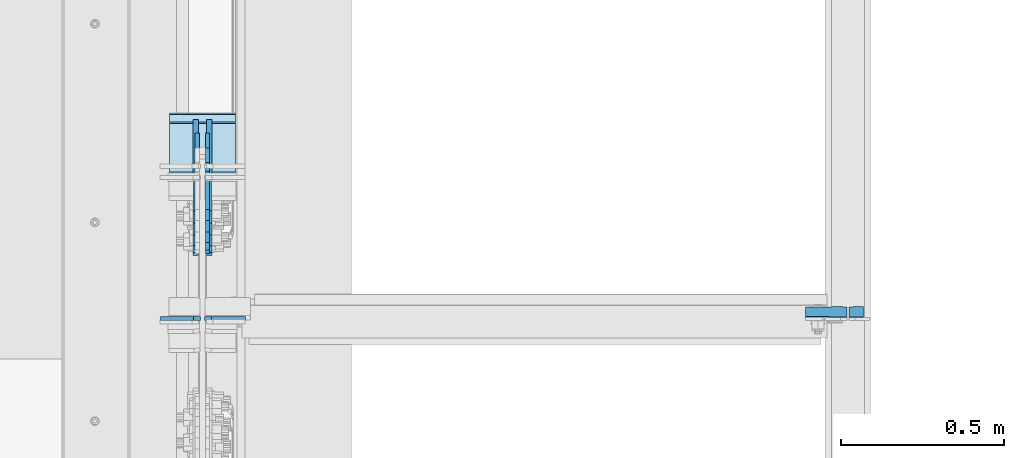
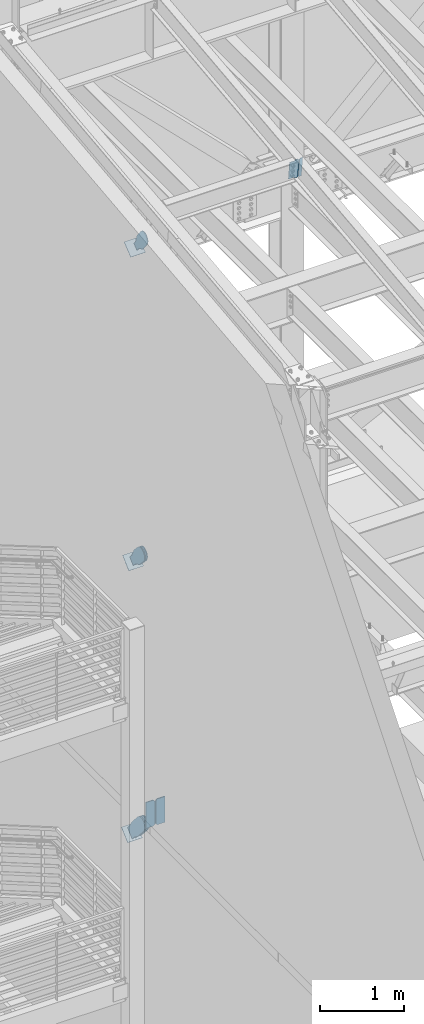
# One storey, part 1025 of 1179: 12 plates, 10 elements without a shape of their own.
"""IFC2X3 building model written with IfcOpenShell, lengths in millimetres."""

from ifc_helpers import new_model, si_unit, frame, origin_with_axes, place, context, subcontext, project, spatial, faceted_brep, material, type_object, element, aggregate, save


model = new_model("IFC2X3")

# Units and contexts
model_context = context("Model", 3, precision=1e-05, world=origin_with_axes())
body_context = subcontext(model_context, "Body", "Model", "MODEL_VIEW")
ifc_project = project(units=[si_unit("LENGTHUNIT", "METRE", prefix="MILLI"), si_unit("AREAUNIT", "SQUARE_METRE"), si_unit("VOLUMEUNIT", "CUBIC_METRE"), si_unit("MASSUNIT", "GRAM", prefix="KILO"), si_unit("TIMEUNIT", "SECOND"), si_unit("PLANEANGLEUNIT", "RADIAN"), si_unit("SOLIDANGLEUNIT", "STERADIAN"), si_unit("THERMODYNAMICTEMPERATUREUNIT", "DEGREE_CELSIUS"), si_unit("LUMINOUSINTENSITYUNIT", "LUMEN")], contexts=[model_context])

# Site, building, storey
site_placement = place(None, origin_with_axes())
site = spatial("IfcSite", under=ifc_project, at=site_placement, CompositionType="ELEMENT")
building_placement = place(site_placement, origin_with_axes())
building = spatial("IfcBuilding", under=site, at=building_placement, Name="Undefined", CompositionType="ELEMENT")
storey_placement = place(building_placement, origin_with_axes())
storey = spatial("IfcBuildingStorey", under=building, at=storey_placement, Name="Undefined", CompositionType="ELEMENT", Elevation=0.0)

# Assembly, plates
assembly_1_placement = place(storey_placement, origin_with_axes())
assembly_1 = element("IfcElementAssembly", 1, at=assembly_1_placement, inside=storey, Name="BEAM", AssemblyPlace="NOTDEFINED", PredefinedType="RIGID_FRAME")
ifc_material_1 = material(Name="STEEL/A36")
plate_type_1 = type_object("IfcPlateType", PredefinedType="NOTDEFINED")
plate_1_placement = place(assembly_1_placement, frame((2416.175, 30762.7083222141, 12422.6760116434), z_axis=(0.0, -0.112284087038017, 0.993676146336441), x_axis=(1.0, 0.0, 0.0)))
plate_1 = element("IfcPlate", 2, at=plate_1_placement, type_object=plate_type_1, material=ifc_material_1, Name="PLATE", context=body_context, shape_type="Brep", body=[
    faceted_brep([(-2.72848410531878e-12, -4.76249999998981, 12.6999998092615), (-5.54791768081486e-11, -4.76249999988249, 273.050000190095), (-5.54791768081486e-11, 4.76250000010987, 273.050000190089), (-2.72848410531878e-12, 4.76250000000437, 12.699999809256), (12.6999998092069, -4.76249999987886, 285.749999999351), (12.6999998092069, 4.76250000011532, 285.749999999349), (44.450000005796, -4.76249999988067, 285.749999998694), (44.450000005796, 4.7625000001135, 285.74999999869), (44.4500000000007, -4.76250000000073, 0.0), (44.4500000000007, 4.76250000000073, 0.0), (12.6999998092651, -4.76249999999527, 1.81898940354586e-12), (12.6999998092651, 4.76250000000073, 0.0)], [[[0, 1, 2, 3]], [[1, 4, 5, 2]], [[4, 6, 7, 5]], [[6, 8, 9, 7]], [[8, 10, 11, 9]], [[10, 0, 3, 11]], [[5, 7, 9, 11, 3, 2]], [[10, 8, 6, 4, 1, 0]]]),
])
plate_type_2 = type_object("IfcPlateType", PredefinedType="NOTDEFINED")
plate_2_placement = place(assembly_1_placement, frame((2409.825, 30730.6226475522, 12706.6189143206), z_axis=(-1.0, 0.0, 0.0), x_axis=(0.0, 0.112284087038014, -0.993676146336441)))
plate_2 = element("IfcPlate", 3, at=plate_2_placement, type_object=plate_type_2, material=ifc_material_1, Name="PLATE", context=body_context, shape_type="Brep", body=[
    faceted_brep([(273.049999995341, -4.76249999988795, 127.0), (273.049999995888, -4.76249999988795, 60.3249998091615), (273.049999995885, 4.76250000010623, 60.3249998091615), (273.049999995339, 4.76250000010623, 127.0), (274.016729918505, -4.76249999988795, 55.4649202911478), (274.0167299185, 4.76250000010623, 55.4649202911478), (276.769743818986, -4.76249999988795, 51.3447438230296), (276.769743818983, 4.76250000010623, 51.3447438230296), (280.889920287118, -4.76249999988431, 48.5917299225785), (280.889920287116, 4.76250000010987, 48.5917299225785), (285.749999805133, -4.76249999988431, 47.6250000000005), (285.749999999514, 4.7625000001135, 47.6250000000005), (12.6999999979416, -4.76249999999345, 127.0), (12.699999997938, 4.76250000000073, 127.0), (12.699999997998, 4.76250000000073, 60.324999809277), (12.6999999980017, -4.76249999999345, 60.324999809277), (11.7332700754141, 4.76250000000073, 55.4649202912278), (11.7332700754177, -4.76249999999345, 55.4649202912278), (8.98025617494022, 4.76249999999709, 51.3447438230705), (8.98025617494568, -4.76249999999345, 51.3447438230705), (4.86007970679384, 4.76249999999709, 48.5917299225894), (4.8600797067993, -4.76249999999709, 48.5917299225894), (-3.63797880709171e-12, 4.76249999999709, 47.6250000000005), (0.0, -4.76250000000073, 47.6250000000005), (-2.72848410531878e-12, 4.76250000000437, 12.699999809256), (-2.72848410531878e-12, -4.76249999998981, 12.6999998092615), (12.6999998092651, -4.76249999999527, 1.81898940354586e-12), (12.6999998092651, 4.76250000000073, 0.0), (273.050000190497, -4.76249999988977, -5.59339241590351e-11), (273.050000190493, 4.76250000010623, -5.59339241590351e-11), (285.749999999753, -4.76249999988249, 12.6999998092065), (285.749999999747, 4.76250000011169, 12.6999998092065)], [[[0, 1, 2, 3]], [[4, 5, 2, 1]], [[6, 7, 5, 4]], [[8, 9, 7, 6]], [[10, 11, 9, 8]], [[12, 13, 14, 15]], [[15, 14, 16, 17]], [[17, 16, 18, 19]], [[19, 18, 20, 21]], [[21, 20, 22, 23]], [[24, 25, 23, 22]], [[26, 25, 24, 27]], [[28, 26, 27, 29]], [[30, 28, 29, 31]], [[6, 4, 1, 0, 12, 15, 17, 19, 21, 23, 25, 26, 28, 30, 10, 8]], [[13, 12, 0, 3]], [[31, 29, 27, 24, 22, 20, 18, 16, 14, 13, 3, 2, 5, 7, 9, 11]], [[30, 31, 11, 10]]]),
])
aggregate(assembly_1, [plate_1, plate_2])

# Assembly, plate
assembly_2_placement = place(storey_placement, origin_with_axes())
assembly_2 = element("IfcElementAssembly", 4, at=assembly_2_placement, inside=storey, AssemblyPlace="NOTDEFINED", PredefinedType="RIGID_FRAME")
plate_type_3 = type_object("IfcPlateType", PredefinedType="NOTDEFINED")
plate_3_placement = place(assembly_2_placement, frame((447.675000000002, 31210.0093415497, 11898.2274613016), z_axis=(0.0, -0.784152810390105, -0.620567780308727), x_axis=(0.0, 0.620567780308723, -0.784152810390108)))
plate_3 = element("IfcPlate", 5, at=plate_3_placement, type_object=plate_type_3, material=ifc_material_1, context=body_context, shape_type="Brep", body=[
    faceted_brep([(0.0, -6.34999999999854, 0.0), (-101.600000000211, -6.34999999999854, -44.6881937825565), (-101.600000000211, 6.34999999999854, -44.6881937825565), (0.0, 6.34999999999854, 0.0), (-246.684985848258, -6.34999999999854, -44.6881937827675), (-246.684985848258, 6.34999999999854, -44.6881937827675), (-281.313054102191, -6.34999999999854, -37.800242748639), (-281.313054102191, 6.34999999999854, -37.800242748639), (-310.669312868691, -6.34999999999854, -18.1850177516608), (-310.669312868691, 6.34999999999854, -18.1850177516608), (-330.284537865713, -6.34999999999854, 11.1712410148393), (-330.284537865713, 6.34999999999854, 11.1712410148393), (-337.172488899912, -6.34999999999854, 45.7993031647638), (-337.172488899912, 6.34999999999854, 45.7993031647638), (-330.284537865768, -6.34999999999854, 80.4273714187839), (-330.284537865768, 6.34999999999854, 80.4273714187839), (-310.669312868773, -6.34999999999854, 109.783630185371), (-310.669312868773, 6.34999999999854, 109.783630185371), (-281.313054102271, -6.34999999999854, 129.398855182466), (-281.313054102271, 6.34999999999854, 129.398855182466), (-246.684988899762, -6.34999999999854, 136.286806216707), (-246.684988899762, 6.34999999999854, 136.286806216707), (-101.600000000377, -6.34999999999854, 136.286806216911), (-101.600000000377, 6.34999999999854, 136.286806216911), (-8.18545231595635e-11, -6.34999999999854, 91.5986124346418), (-8.18545231595635e-11, 6.34999999999854, 91.5986124346418), (71.7550000025622, -6.35000000000002, 91.5986124349001), (71.7550000025622, 6.35000000000002, 91.5986124349001), (71.7550000025931, -6.35000000000002, 1.09139364212751e-10), (71.7550000025931, 6.35000000000002, 1.09139364212751e-10)], [[[0, 1, 2, 3]], [[1, 4, 5, 2]], [[4, 6, 7, 5]], [[6, 8, 9, 7]], [[8, 10, 11, 9]], [[10, 12, 13, 11]], [[12, 14, 15, 13]], [[14, 16, 17, 15]], [[16, 18, 19, 17]], [[18, 20, 21, 19]], [[20, 22, 23, 21]], [[22, 24, 25, 23]], [[24, 26, 27, 25]], [[26, 28, 29, 27]], [[28, 0, 3, 29]], [[5, 7, 9, 11, 13, 15, 17, 19, 21, 23, 25, 27, 29, 3, 2]], [[28, 26, 24, 22, 20, 18, 16, 14, 12, 10, 8, 6, 4, 1, 0]]]),
])
aggregate(assembly_2, [plate_3])

assembly_3_placement = place(storey_placement, origin_with_axes())
assembly_3 = element("IfcElementAssembly", 6, at=assembly_3_placement, inside=storey, Name="Plate", AssemblyPlace="NOTDEFINED", PredefinedType="RIGID_FRAME")
plate_type_4 = type_object("IfcPlateType", PredefinedType="NOTDEFINED")
plate_4_placement = place(assembly_3_placement, frame((330.200000000002, 31136.984299702, 11752.9790012819), z_axis=(0.0, 0.784152810390107, 0.620567780308724), x_axis=(1.0, 0.0, 0.0)))
plate_4 = element("IfcPlate", 7, at=plate_4_placement, type_object=plate_type_4, material=ifc_material_1, Name="Plate", context=body_context, shape_type="Brep", body=[
    faceted_brep([(0.0, -3.17500000000109, 0.0), (0.0, -3.17500000000291, 203.200000000368), (0.0, 3.17499999998836, 203.200000000361), (0.0, 3.17500000000109, 7.27595761418343e-12), (203.199999999997, -3.17500000000291, 203.200000000368), (203.199999999997, 3.17499999998836, 203.200000000361), (203.199999999997, -3.17499999999927, 3.63797880709171e-12), (203.199999999997, 3.17499999999382, -3.63797880709171e-12)], [[[0, 1, 2, 3]], [[1, 4, 5, 2]], [[4, 6, 7, 5]], [[6, 0, 3, 7]], [[5, 7, 3, 2]], [[6, 4, 1, 0]]]),
])
aggregate(assembly_3, [plate_4])

assembly_4_placement = place(storey_placement, origin_with_axes())
assembly_4 = element("IfcElementAssembly", 8, at=assembly_4_placement, inside=storey, Name="Plate", AssemblyPlace="NOTDEFINED", PredefinedType="RIGID_FRAME")
plate_5_placement = place(assembly_4_placement, frame((330.200000000002, 31183.7164897158, 7162.85000799674), z_axis=(0.0, 0.729241792887681, 0.684256097894612), x_axis=(1.0, 0.0, 0.0)))
plate_5 = element("IfcPlate", 9, at=plate_5_placement, type_object=plate_type_4, material=ifc_material_1, Name="Plate", context=body_context, shape_type="Brep", body=[
    faceted_brep([(0.0, -3.17500000000109, 0.0), (0.0, -3.17500000000291, 203.200000000368), (0.0, 3.17499999998836, 203.200000000361), (0.0, 3.17500000000109, 7.27595761418343e-12), (203.199999999997, -3.17500000000291, 203.200000000368), (203.199999999997, 3.17499999998836, 203.200000000361), (203.199999999997, -3.17499999999927, 3.63797880709171e-12), (203.199999999997, 3.17499999999382, -3.63797880709171e-12)], [[[0, 1, 2, 3]], [[1, 4, 5, 2]], [[4, 6, 7, 5]], [[6, 0, 3, 7]], [[5, 7, 3, 2]], [[6, 4, 1, 0]]]),
])
aggregate(assembly_4, [plate_5])

assembly_5_placement = place(storey_placement, origin_with_axes())
assembly_5 = element("IfcElementAssembly", 10, at=assembly_5_placement, inside=storey, Name="Plate", AssemblyPlace="NOTDEFINED", PredefinedType="RIGID_FRAME")
plate_6_placement = place(assembly_5_placement, frame((330.200000000002, 31208.7365914603, 3194.42286843923), z_axis=(0.0, 0.745753571678113, 0.666221892712434), x_axis=(1.0, 0.0, 0.0)))
plate_6 = element("IfcPlate", 11, at=plate_6_placement, type_object=plate_type_4, material=ifc_material_1, Name="Plate", context=body_context, shape_type="Brep", body=[
    faceted_brep([(0.0, -3.17500000000109, 0.0), (0.0, -3.17500000000291, 203.200000000368), (0.0, 3.17499999998836, 203.200000000361), (0.0, 3.17500000000109, 7.27595761418343e-12), (203.199999999997, -3.17500000000291, 203.200000000368), (203.199999999997, 3.17499999998836, 203.200000000361), (203.199999999997, -3.17499999999927, 3.63797880709171e-12), (203.199999999997, 3.17499999999382, -3.63797880709171e-12)], [[[0, 1, 2, 3]], [[1, 4, 5, 2]], [[4, 6, 7, 5]], [[6, 0, 3, 7]], [[5, 7, 3, 2]], [[6, 4, 1, 0]]]),
])
aggregate(assembly_5, [plate_6])

assembly_6_placement = place(storey_placement, origin_with_axes())
assembly_6 = element("IfcElementAssembly", 12, at=assembly_6_placement, inside=storey, Name="BEAM", AssemblyPlace="NOTDEFINED", PredefinedType="RIGID_FRAME")
ifc_material_2 = material(Name="STEEL/A572-GR.50")
plate_type_5 = type_object("IfcPlateType", PredefinedType="NOTDEFINED")
plate_7_placement = place(assembly_6_placement, frame((437.356250000002, 30730.825, 3703.6375), z_axis=(0.0, 0.0, 1.0), x_axis=(1.0, 0.0, 0.0)))
plate_7 = element("IfcPlate", 13, at=plate_7_placement, type_object=plate_type_5, material=ifc_material_2, Name="PLATE", context=body_context, shape_type="Brep", body=[
    faceted_brep([(0.0, -6.34999999999854, 22.2250003814697), (0.0, -6.34999999999854, 355.600011825562), (0.0, 6.34999999999854, 355.600011825562), (0.0, 6.34999999999854, 22.2250003814697), (22.2250003814697, -6.34999999999854, 377.825012207031), (22.2250003814697, 6.34999999999854, 377.825012207031), (127.000004873051, -6.34999999999854, 377.825), (127.000004873051, 6.34999999999854, 377.825), (127.000004873051, -6.34999999999854, 0.0), (127.000004873051, 6.34999999999854, 0.0), (22.2250003814697, -6.34999999999854, 0.0), (22.2250003814697, 6.34999999999854, 0.0)], [[[0, 1, 2, 3]], [[1, 4, 5, 2]], [[4, 6, 7, 5]], [[6, 8, 9, 7]], [[8, 10, 11, 9]], [[10, 0, 3, 11]], [[5, 7, 9, 11, 3, 2]], [[10, 8, 6, 4, 1, 0]]]),
])

assembly_7_placement = place(storey_placement, origin_with_axes())
assembly_7 = element("IfcElementAssembly", 14, at=assembly_7_placement, inside=storey, AssemblyPlace="NOTDEFINED", PredefinedType="RIGID_FRAME")
plate_type_6 = type_object("IfcPlateType", PredefinedType="NOTDEFINED")
plate_8_placement = place(assembly_7_placement, frame((415.925000000002, 31244.3995981522, 7328.63560634023), z_axis=(0.0, -0.729241792887679, -0.684256097894614), x_axis=(0.0, 0.684256097894613, -0.72924179288768)))
plate_8 = element("IfcPlate", 15, at=plate_8_placement, type_object=plate_type_6, material=ifc_material_1, context=body_context, shape_type="Brep", body=[
    faceted_brep([(0.0, -6.34999999999854, 0.0), (-101.599999999963, -6.34999999999854, -37.5700345970108), (-101.599999999963, 6.34999999999854, -37.5700345970108), (0.0, 6.34999999999854, 0.0), (-245.369242323884, -6.34999999999854, -37.5700345970945), (-245.369242323884, 6.34999999999854, -37.5700345970945), (-281.212328723803, -6.34999999999854, -30.4404014271258), (-281.212328723803, 6.34999999999854, -30.4404014271258), (-311.598630137756, -6.34999999999854, -10.1369239370142), (-311.598630137756, 6.34999999999854, -10.1369239370142), (-331.902107627997, -6.34999999999854, 20.24937747687), (-331.902107627997, 6.34999999999854, 20.24937747687), (-339.031740798124, -6.34999999999854, 56.0924669287269), (-339.031740798124, 6.34999999999854, 56.0924669287269), (-331.902107628228, -6.34999999999854, 91.9355533287926), (-331.902107628228, 6.34999999999854, 91.9355533287926), (-311.598630138099, -6.34999999999854, 122.321854742866), (-311.598630138099, 6.34999999999854, 122.321854742866), (-281.212328724136, -6.34999999999854, 142.625332233139), (-281.212328724136, 6.34999999999854, 142.625332233139), (-245.36924079839, -6.34999999999854, 149.754965403199), (-245.36924079839, 6.34999999999854, 149.754965403199), (-101.600000000685, -6.34999999999854, 149.75496540329), (-101.600000000685, 6.34999999999854, 149.75496540329), (-4.35647962149233e-10, -6.34999999999854, 112.184930806416), (-4.35647962149233e-10, 6.34999999999854, 112.184930806416), (82.5499999996491, -6.34999999999854, 112.184930806461), (82.5499999996491, 6.34999999999854, 112.184930806461), (82.550000000203, -6.34999999999854, 1.2732925824821e-10), (82.550000000203, 6.34999999999854, 1.2732925824821e-10)], [[[0, 1, 2, 3]], [[1, 4, 5, 2]], [[4, 6, 7, 5]], [[6, 8, 9, 7]], [[8, 10, 11, 9]], [[10, 12, 13, 11]], [[12, 14, 15, 13]], [[14, 16, 17, 15]], [[16, 18, 19, 17]], [[18, 20, 21, 19]], [[20, 22, 23, 21]], [[22, 24, 25, 23]], [[24, 26, 27, 25]], [[26, 28, 29, 27]], [[28, 0, 3, 29]], [[5, 7, 9, 11, 13, 15, 17, 19, 21, 23, 25, 27, 29, 3, 2]], [[28, 26, 24, 22, 20, 18, 16, 14, 12, 10, 8, 6, 4, 1, 0]]]),
])
aggregate(assembly_7, [plate_8])

assembly_8_placement = place(storey_placement, origin_with_axes())
assembly_8 = element("IfcElementAssembly", 16, at=assembly_8_placement, inside=storey, AssemblyPlace="NOTDEFINED", PredefinedType="RIGID_FRAME")
plate_9_placement = place(assembly_8_placement, frame((447.675000000002, 31244.3995981522, 7328.63560634023), z_axis=(0.0, -0.729241792887679, -0.684256097894614), x_axis=(0.0, 0.684256097894613, -0.72924179288768)))
plate_9 = element("IfcPlate", 17, at=plate_9_placement, type_object=plate_type_6, material=ifc_material_1, context=body_context, shape_type="Brep", body=[
    faceted_brep([(0.0, -6.34999999999854, 0.0), (-101.599999999963, -6.34999999999854, -37.5700345970108), (-101.599999999963, 6.34999999999854, -37.5700345970108), (0.0, 6.34999999999854, 0.0), (-245.369242323884, -6.34999999999854, -37.5700345970945), (-245.369242323884, 6.34999999999854, -37.5700345970945), (-281.212328723803, -6.34999999999854, -30.4404014271258), (-281.212328723803, 6.34999999999854, -30.4404014271258), (-311.598630137756, -6.34999999999854, -10.1369239370142), (-311.598630137756, 6.34999999999854, -10.1369239370142), (-331.902107627997, -6.34999999999854, 20.24937747687), (-331.902107627997, 6.34999999999854, 20.24937747687), (-339.031740798124, -6.34999999999854, 56.0924669287269), (-339.031740798124, 6.34999999999854, 56.0924669287269), (-331.902107628228, -6.34999999999854, 91.9355533287926), (-331.902107628228, 6.34999999999854, 91.9355533287926), (-311.598630138099, -6.34999999999854, 122.321854742866), (-311.598630138099, 6.34999999999854, 122.321854742866), (-281.212328724136, -6.34999999999854, 142.625332233139), (-281.212328724136, 6.34999999999854, 142.625332233139), (-245.36924079839, -6.34999999999854, 149.754965403199), (-245.36924079839, 6.34999999999854, 149.754965403199), (-101.600000000685, -6.34999999999854, 149.75496540329), (-101.600000000685, 6.34999999999854, 149.75496540329), (-4.35647962149233e-10, -6.34999999999854, 112.184930806416), (-4.35647962149233e-10, 6.34999999999854, 112.184930806416), (82.5499999996491, -6.34999999999854, 112.184930806461), (82.5499999996491, 6.34999999999854, 112.184930806461), (82.550000000203, -6.34999999999854, 1.2732925824821e-10), (82.550000000203, 6.34999999999854, 1.2732925824821e-10)], [[[0, 1, 2, 3]], [[1, 4, 5, 2]], [[4, 6, 7, 5]], [[6, 8, 9, 7]], [[8, 10, 11, 9]], [[10, 12, 13, 11]], [[12, 14, 15, 13]], [[14, 16, 17, 15]], [[16, 18, 19, 17]], [[18, 20, 21, 19]], [[20, 22, 23, 21]], [[22, 24, 25, 23]], [[24, 26, 27, 25]], [[26, 28, 29, 27]], [[28, 0, 3, 29]], [[5, 7, 9, 11, 13, 15, 17, 19, 21, 23, 25, 27, 29, 3, 2]], [[28, 26, 24, 22, 20, 18, 16, 14, 12, 10, 8, 6, 4, 1, 0]]]),
])
aggregate(assembly_8, [plate_9])

assembly_9_placement = place(storey_placement, origin_with_axes())
assembly_9 = element("IfcElementAssembly", 18, at=assembly_9_placement, inside=storey, AssemblyPlace="NOTDEFINED", PredefinedType="RIGID_FRAME")
plate_type_7 = type_object("IfcPlateType", PredefinedType="NOTDEFINED")
plate_10_placement = place(assembly_9_placement, frame((411.162500000002, 31288.0933998849, 3368.34659880869), z_axis=(0.0, -0.74575357167811, -0.666221892712438), x_axis=(0.0, 0.666221892712438, -0.74575357167811)))
plate_10 = element("IfcPlate", 19, at=plate_10_placement, type_object=plate_type_7, material=ifc_material_1, context=body_context, shape_type="Brep", body=[
    faceted_brep([(0.0, -7.9375, 0.0), (-101.600000000497, -7.9375, -21.7975798445477), (-101.600000000497, 7.9375, -21.7975798445477), (0.0, 7.9375, 0.0), (-320.921138851689, -7.9375, -21.7975798443877), (-320.921138851689, 7.9375, -21.7975798443877), (-357.371735784433, -7.9375, -14.5471053160727), (-357.371735784433, 7.9375, -14.5471053160727), (-388.273059759649, -7.9375, 6.10049924760824), (-388.273059759649, 7.9375, 6.10049924760824), (-408.920664323319, -7.9375, 37.0018232228431), (-408.920664323319, 7.9375, 37.0018232228431), (-416.171138851623, -7.9375, 73.4524201546446), (-416.171138851623, 7.9375, 73.4524201546446), (-408.920664323337, -7.9375, 109.903017087447), (-408.920664323337, 7.9375, 109.903017087447), (-388.273059759656, -7.9375, 140.804341062707), (-388.273059759656, 7.9375, 140.804341062707), (-357.3717357844, -7.9375, 161.451945626395), (-357.3717357844, 7.9375, 161.451945626395), (-320.921138851201, -7.9375, 168.702420154674), (-320.921138851201, 7.9375, 168.702420154674), (-101.600000000592, -7.9375, 168.702420154521), (-101.600000000592, 7.9375, 168.702420154521), (-8.00355337560177e-11, -7.9375, 146.904840309817), (-8.00355337560177e-11, 7.9375, 146.904840309817), (80.0100000003295, -7.9375, 146.904840309766), (80.0100000003295, 7.9375, 146.904840309766), (80.0100000004022, -7.9375, -5.82076609134674e-11), (80.0100000004022, 7.9375, -5.82076609134674e-11)], [[[0, 1, 2, 3]], [[1, 4, 5, 2]], [[4, 6, 7, 5]], [[6, 8, 9, 7]], [[8, 10, 11, 9]], [[10, 12, 13, 11]], [[12, 14, 15, 13]], [[14, 16, 17, 15]], [[16, 18, 19, 17]], [[18, 20, 21, 19]], [[20, 22, 23, 21]], [[22, 24, 25, 23]], [[24, 26, 27, 25]], [[26, 28, 29, 27]], [[28, 0, 3, 29]], [[5, 7, 9, 11, 13, 15, 17, 19, 21, 23, 25, 27, 29, 3, 2]], [[28, 26, 24, 22, 20, 18, 16, 14, 12, 10, 8, 6, 4, 1, 0]]]),
])
aggregate(assembly_9, [plate_10])

assembly_10_placement = place(storey_placement, origin_with_axes())
assembly_10 = element("IfcElementAssembly", 20, at=assembly_10_placement, inside=storey, AssemblyPlace="NOTDEFINED", PredefinedType="RIGID_FRAME")
plate_11_placement = place(assembly_10_placement, frame((452.437500000002, 31288.0933998849, 3368.34659880869), z_axis=(0.0, -0.74575357167811, -0.666221892712438), x_axis=(0.0, 0.666221892712438, -0.74575357167811)))
plate_11 = element("IfcPlate", 21, at=plate_11_placement, type_object=plate_type_7, material=ifc_material_1, context=body_context, shape_type="Brep", body=[
    faceted_brep([(0.0, -7.9375, 0.0), (-101.600000000497, -7.9375, -21.7975798445477), (-101.600000000497, 7.9375, -21.7975798445477), (0.0, 7.9375, 0.0), (-320.921138851689, -7.9375, -21.7975798443877), (-320.921138851689, 7.9375, -21.7975798443877), (-357.371735784433, -7.9375, -14.5471053160727), (-357.371735784433, 7.9375, -14.5471053160727), (-388.273059759649, -7.9375, 6.10049924760824), (-388.273059759649, 7.9375, 6.10049924760824), (-408.920664323319, -7.9375, 37.0018232228431), (-408.920664323319, 7.9375, 37.0018232228431), (-416.171138851623, -7.9375, 73.4524201546446), (-416.171138851623, 7.9375, 73.4524201546446), (-408.920664323337, -7.9375, 109.903017087447), (-408.920664323337, 7.9375, 109.903017087447), (-388.273059759656, -7.9375, 140.804341062707), (-388.273059759656, 7.9375, 140.804341062707), (-357.3717357844, -7.9375, 161.451945626395), (-357.3717357844, 7.9375, 161.451945626395), (-320.921138851201, -7.9375, 168.702420154674), (-320.921138851201, 7.9375, 168.702420154674), (-101.600000000592, -7.9375, 168.702420154521), (-101.600000000592, 7.9375, 168.702420154521), (-8.00355337560177e-11, -7.9375, 146.904840309817), (-8.00355337560177e-11, 7.9375, 146.904840309817), (80.0100000003295, -7.9375, 146.904840309766), (80.0100000003295, 7.9375, 146.904840309766), (80.0100000004022, -7.9375, -5.82076609134674e-11), (80.0100000004022, 7.9375, -5.82076609134674e-11)], [[[0, 1, 2, 3]], [[1, 4, 5, 2]], [[4, 6, 7, 5]], [[6, 8, 9, 7]], [[8, 10, 11, 9]], [[10, 12, 13, 11]], [[12, 14, 15, 13]], [[14, 16, 17, 15]], [[16, 18, 19, 17]], [[18, 20, 21, 19]], [[20, 22, 23, 21]], [[22, 24, 25, 23]], [[24, 26, 27, 25]], [[26, 28, 29, 27]], [[28, 0, 3, 29]], [[5, 7, 9, 11, 13, 15, 17, 19, 21, 23, 25, 27, 29, 3, 2]], [[28, 26, 24, 22, 20, 18, 16, 14, 12, 10, 8, 6, 4, 1, 0]]]),
])
aggregate(assembly_10, [plate_11])

# Plate
plate_type_8 = type_object("IfcPlateType", PredefinedType="NOTDEFINED")
plate_12_placement = place(assembly_6_placement, frame((426.243750000002, 30730.825, 3703.6375), z_axis=(0.0, 0.0, 1.0), x_axis=(-1.0, 0.0, 0.0)))
plate_12 = element("IfcPlate", 22, at=plate_12_placement, type_object=plate_type_8, material=ifc_material_2, Name="PLATE", context=body_context, shape_type="Brep", body=[
    faceted_brep([(0.0, -6.34999999999854, 22.2250003814697), (0.0, -6.34999999999854, 355.600011825562), (0.0, 6.34999999999854, 355.600011825562), (0.0, 6.34999999999854, 22.2250003814697), (22.2250003814697, -6.34999999999854, 377.825012207031), (22.2250003814697, 6.34999999999854, 377.825012207031), (123.03125, -6.34999999999854, 377.825012207031), (123.03125, 6.34999999999854, 377.825012207031), (123.03125, -6.34999999999854, 0.0), (123.03125, 6.34999999999854, 0.0), (22.2250003814697, -6.34999999999854, 0.0), (22.2250003814697, 6.34999999999854, 0.0)], [[[0, 1, 2, 3]], [[1, 4, 5, 2]], [[4, 6, 7, 5]], [[6, 8, 9, 7]], [[8, 10, 11, 9]], [[10, 0, 3, 11]], [[5, 7, 9, 11, 3, 2]], [[10, 8, 6, 4, 1, 0]]]),
])

aggregate(assembly_6, [plate_12, plate_7])

save(model, "model.ifc")
